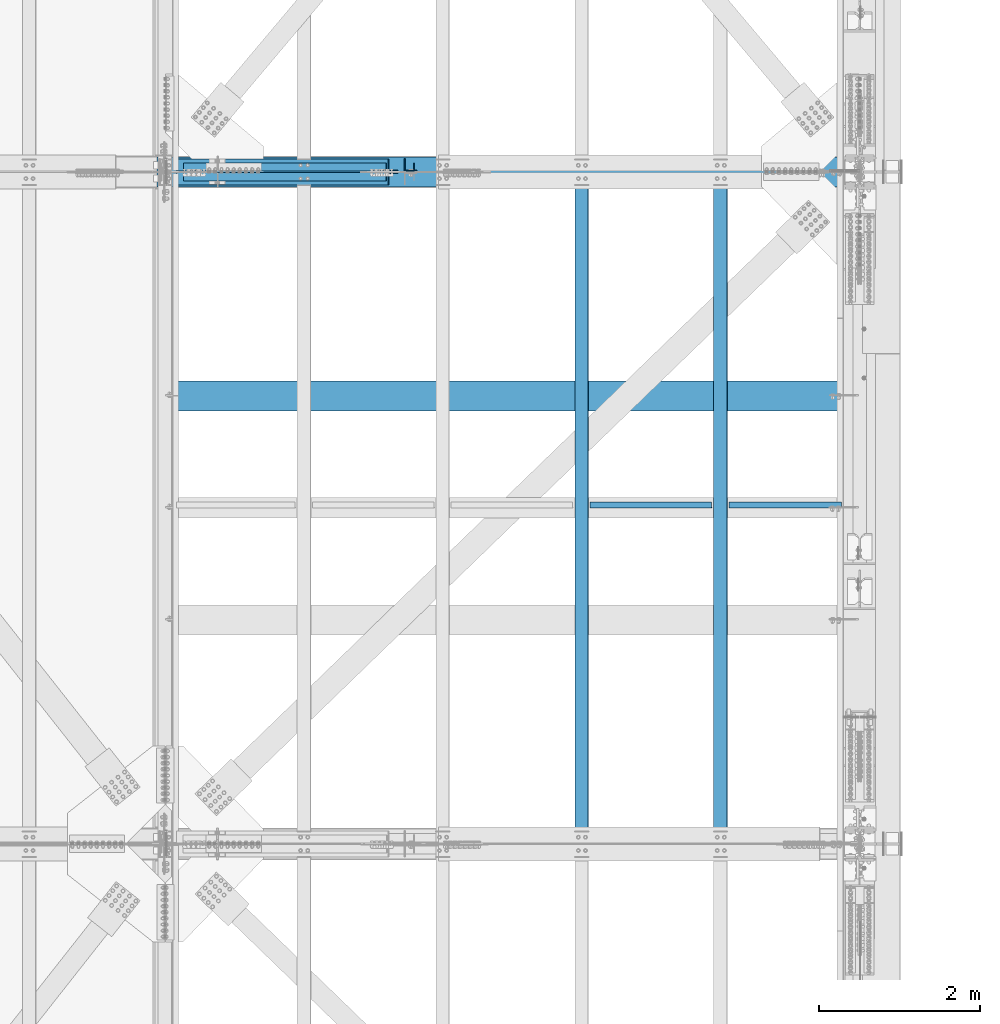
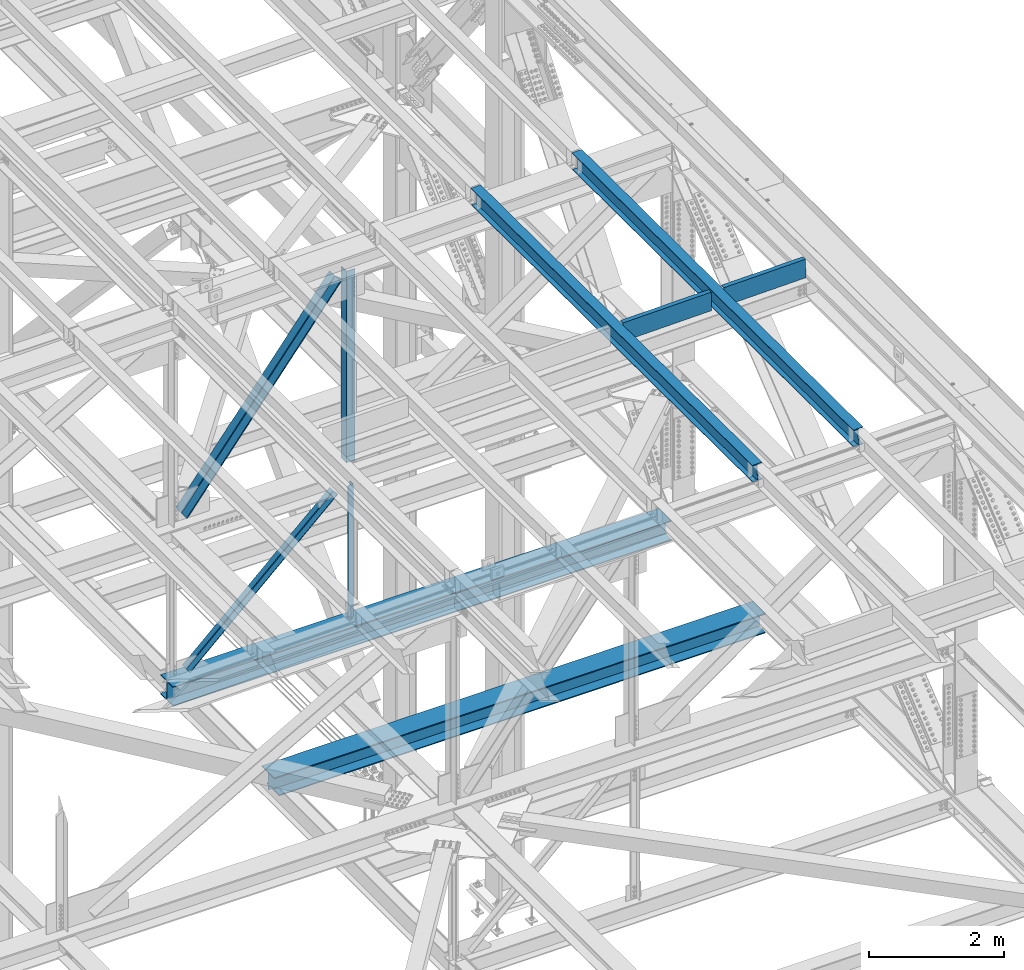
# One storey, part 1983 of 3843: 8 beams, 4 members, 12 elements without a shape of their own.
"""IFC2X3 building model written with IfcOpenShell, lengths in millimetres."""

from ifc_helpers import new_model, si_unit, frame, origin_with_axes, place, context, subcontext, project, spatial, faceted_brep, material, type_object, element, aggregate, save


model = new_model("IFC2X3")

# Units and contexts
model_context = context("Model", 3, precision=1e-05, world=origin_with_axes())
body_context = subcontext(model_context, "Body", "Model", "MODEL_VIEW")
ifc_project = project(units=[si_unit("LENGTHUNIT", "METRE", prefix="MILLI"), si_unit("AREAUNIT", "SQUARE_METRE"), si_unit("VOLUMEUNIT", "CUBIC_METRE"), si_unit("MASSUNIT", "GRAM", prefix="KILO"), si_unit("TIMEUNIT", "SECOND"), si_unit("PLANEANGLEUNIT", "RADIAN"), si_unit("SOLIDANGLEUNIT", "STERADIAN"), si_unit("THERMODYNAMICTEMPERATUREUNIT", "DEGREE_CELSIUS"), si_unit("LUMINOUSINTENSITYUNIT", "LUMEN")], contexts=[model_context])

# Site, building, storey
site_placement = place(None, origin_with_axes())
site = spatial("IfcSite", under=ifc_project, at=site_placement, CompositionType="ELEMENT")
building_placement = place(site_placement, origin_with_axes())
building = spatial("IfcBuilding", under=site, at=building_placement, Name="Undefined", CompositionType="ELEMENT")
storey_placement = place(building_placement, origin_with_axes())
storey = spatial("IfcBuildingStorey", under=building, at=storey_placement, Name="Undefined", CompositionType="ELEMENT", Elevation=0.0)

# Assembly, beam
assembly_1_placement = place(storey_placement, origin_with_axes())
assembly_1 = element("IfcElementAssembly", 1, at=assembly_1_placement, inside=storey, Name="ANGLE", AssemblyPlace="NOTDEFINED", PredefinedType="RIGID_FRAME")
ifc_material_1 = material(Name="STEEL/A572-50")
beam_type_1 = type_object("IfcBeamType", Name="L4X4X3/8", PredefinedType="NOTDEFINED")
beam_1_placement = place(assembly_1_placement, frame((80060.8, 84045.425, 42300.6667680656), z_axis=(-1.0, 0.0, 0.0), x_axis=(0.0, 0.0, -1.0)))
beam_1 = element("IfcBeam", 2, at=beam_1_placement, type_object=beam_type_1, material=ifc_material_1, Name="ANGLE", ObjectType="L4X4X3/8", context=body_context, shape_type="Brep", body=[
    faceted_brep([(248.754579143424, 50.8000000000029, -50.8000000000029), (248.754579143424, 50.8000000000029, 50.8000000000029), (2642.60848138916, 50.8000000000029, 50.8000000000029), (2642.60848138916, 50.8000000000029, -50.8000000000029), (248.754579143424, 41.2749999999942, 50.8000000000029), (2642.60848138916, 41.2749999999942, 50.8000000000029), (248.754579143424, 41.2749999999942, -41.2749999999942), (2642.60848138916, 41.2749999999942, -41.2749999999942), (248.754579143424, -50.8000000000029, -41.2749999999942), (2642.60848138916, -50.8000000000029, -41.2749999999942), (248.754579143424, -50.8000000000029, -50.8000000000029), (2642.60848138916, -50.8000000000029, -50.8000000000029)], [[[0, 1, 2, 3]], [[1, 4, 5, 2]], [[4, 6, 7, 5]], [[6, 8, 9, 7]], [[8, 10, 11, 9]], [[10, 0, 3, 11]], [[5, 7, 9, 11, 3, 2]], [[10, 8, 6, 4, 1, 0]]]),
])
aggregate(assembly_1, [beam_1])

assembly_2_placement = place(storey_placement, origin_with_axes())
assembly_2 = element("IfcElementAssembly", 3, at=assembly_2_placement, inside=storey, Name="BEAM", AssemblyPlace="NOTDEFINED", PredefinedType="RIGID_FRAME")
ifc_material_2 = material(Name="STEEL/A992")
beam_type_2 = type_object("IfcBeamType", Name="W12X26", PredefinedType="NOTDEFINED")
beam_2_placement = place(assembly_2_placement, frame((83918.3092626788, 75629.1553872988, 46633.4435819886), z_axis=(-0.0211520977821055, 0.00421267700001771, 0.99976739400318), x_axis=(0.0, 0.99999112266385, -0.00421361999858334)))
beam_2 = element("IfcBeam", 4, at=beam_2_placement, type_object=beam_type_2, material=ifc_material_2, Name="BEAM", ObjectType="W12X26", context=body_context, shape_type="Brep", body=[
    faceted_brep([(12.7074702028913, 82.5500000014144, -155.574999999284), (12.667344095622, 82.5500000013417, -146.049999999312), (8343.94130358995, 82.550000001429, -146.050000003372), (8343.98142969722, 82.5500000015018, -155.575000003337), (12.660269584725, 3.17500000091968, -146.04999999953), (8343.93422907904, 3.17500000100699, -146.050000003583), (11.4297356284951, 3.17499999911524, 146.049999999537), (8342.70369512282, 3.174999999188, 146.049999995485), (11.436810139392, 82.5499999995518, 146.049999999741), (8342.71076963372, 82.5499999996246, 146.049999995688), (11.3966840321373, 82.5499999994936, 155.574999999713), (8342.67064352645, 82.5499999995664, 155.574999995661), (11.3819690494565, -82.5500000013999, 155.574999999269), (8342.65592854377, -82.5500000013126, 155.574999995217), (11.4220951567113, -82.5500000013271, 146.049999999297), (8342.69605465104, -82.5500000012544, 146.049999995244), (11.4291696676228, -3.17500000090513, 146.049999999508), (8342.70312916195, -3.17500000083237, 146.049999995455), (12.6597036238527, -3.1749999991298, -146.049999999545), (8343.93366311816, -3.17499999904248, -146.050000003605), (12.6526291129412, -82.5499999995518, -146.049999999763), (8343.92658860727, -82.5499999994645, -146.050000003823), (12.6927552202105, -82.5499999994936, -155.574999999735), (8343.96671471454, -82.5499999994063, -155.575000003788)], [[[0, 1, 2, 3]], [[1, 4, 5, 2]], [[4, 6, 7, 5]], [[6, 8, 9, 7]], [[8, 10, 11, 9]], [[10, 12, 13, 11]], [[12, 14, 15, 13]], [[14, 16, 17, 15]], [[16, 18, 19, 17]], [[18, 20, 21, 19]], [[20, 22, 23, 21]], [[22, 0, 3, 23]], [[5, 7, 9, 11, 13, 15, 17, 19, 21, 23, 3, 2]], [[22, 20, 18, 16, 14, 12, 10, 8, 6, 4, 1, 0]]]),
])
aggregate(assembly_2, [beam_2])

assembly_3_placement = place(storey_placement, origin_with_axes())
assembly_3 = element("IfcElementAssembly", 5, at=assembly_3_placement, inside=storey, Name="BEAM", AssemblyPlace="NOTDEFINED", PredefinedType="RIGID_FRAME")
beam_3_placement = place(assembly_3_placement, frame((82191.1092624226, 75629.2591768554, 46601.4357541204), z_axis=(-0.0211520979627239, 0.00487981300159298, 0.999764360325394), x_axis=(0.0, 0.999988088312239, -0.00488090500152411)))
beam_3 = element("IfcBeam", 6, at=beam_3_placement, type_object=beam_type_2, material=ifc_material_2, Name="BEAM", ObjectType="W12X26", context=body_context, shape_type="Brep", body=[
    faceted_brep([(12.7086740090017, 82.5500000002503, -155.575000000361), (12.6621932365233, 82.5500000002503, -146.05000000033), (8343.96143305908, 82.549999999741, -146.049999975774), (8344.00791383155, 82.5499999997264, -155.574999975805), (12.6539983546681, 3.17499999981374, -146.050000000381), (8343.95323817723, 3.17499999928987, -146.049999975825), (11.2285879990668, 3.17500000020664, 146.050000000454), (8342.52782782161, 3.17499999969732, 146.050000025025), (11.2367828809074, 82.5500000006577, 146.050000000505), (8342.53602270348, 82.5500000001339, 146.050000025069), (11.1903021084581, 82.5500000006577, 155.575000000536), (8342.48954193101, 82.5500000001484, 155.575000025092), (11.1732567542058, -82.5500000002503, 155.575000000441), (8342.47249657677, -82.5500000007596, 155.57500002499), (11.2197375266551, -82.5500000002648, 146.050000000403), (8342.51897734923, -82.5500000007887, 146.050000024959), (11.2279324085102, -3.17499999982829, 146.050000000461), (8342.52717223109, -3.1750000003376, 146.05000002501), (12.6533427641261, -3.17500000023574, -146.050000000381), (8343.9525825867, -3.17500000074506, -146.049999975825), (12.645147882271, -82.5500000006723, -146.050000000432), (8343.94438770485, -82.5500000011962, -146.049999975876), (12.6916286547494, -82.5500000006869, -155.575000000455), (8343.9908684773, -82.5500000011962, -155.574999975892)], [[[0, 1, 2, 3]], [[1, 4, 5, 2]], [[4, 6, 7, 5]], [[6, 8, 9, 7]], [[8, 10, 11, 9]], [[10, 12, 13, 11]], [[12, 14, 15, 13]], [[14, 16, 17, 15]], [[16, 18, 19, 17]], [[18, 20, 21, 19]], [[20, 22, 23, 21]], [[22, 0, 3, 23]], [[5, 7, 9, 11, 13, 15, 17, 19, 21, 23, 3, 2]], [[22, 20, 18, 16, 14, 12, 10, 8, 6, 4, 1, 0]]]),
])
aggregate(assembly_3, [beam_3])

# Assembly, member
assembly_4_placement = place(storey_placement, origin_with_axes())
assembly_4 = element("IfcElementAssembly", 7, at=assembly_4_placement, inside=storey, Name="ANGLE", AssemblyPlace="NOTDEFINED", PredefinedType="RIGID_FRAME")
member_type_1 = type_object("IfcMemberType", Name="L4X4X3/8", PredefinedType="NOTDEFINED")
member_1_placement = place(assembly_4_placement, frame((80060.8, 84045.425, 42267.545116169), z_axis=(0.0, 1.0, 0.0), x_axis=(-0.733899008140415, 0.0, -0.679258600129962)))
member_1 = element("IfcMember", 8, at=member_1_placement, type_object=member_type_1, material=ifc_material_1, Name="ANGLE", ObjectType="L4X4X3/8", context=body_context, shape_type="Brep", body=[
    faceted_brep([(363.598779794396, 50.7999999975509, -50.8000000000029), (363.598779794396, 50.7999999975509, 50.8000000000029), (3797.94778411629, 50.7999999761196, 50.8000000000029), (3797.94778411629, 50.7999999761196, -50.8000000000029), (363.598779794484, 41.2749999975786, 50.8000000000029), (3797.94778411639, 41.2749999761545, 50.8000000000029), (363.598779794484, 41.2749999975786, -41.2750000000015), (3797.94778411639, 41.2749999761545, -41.2750000000015), (363.598779795444, -50.8000000021093, -41.2750000000015), (3797.94778411734, -50.8000000235443, -41.2750000000015), (363.598779795444, -50.8000000021093, -50.8000000000029), (3797.94778411734, -50.8000000235443, -50.8000000000029)], [[[0, 1, 2, 3]], [[1, 4, 5, 2]], [[4, 6, 7, 5]], [[6, 8, 9, 7]], [[8, 10, 11, 9]], [[10, 0, 3, 11]], [[5, 7, 9, 11, 3, 2]], [[10, 8, 6, 4, 1, 0]]]),
])
aggregate(assembly_4, [member_1])

assembly_5_placement = place(storey_placement, origin_with_axes())
assembly_5 = element("IfcElementAssembly", 9, at=assembly_5_placement, inside=storey, Name="ANGLE", AssemblyPlace="NOTDEFINED", PredefinedType="RIGID_FRAME")
member_2_placement = place(assembly_5_placement, frame((77012.7999999579, 83924.775, 39446.4754725817), z_axis=(0.0, -1.0, 0.0), x_axis=(0.733899008140419, 0.0, 0.679258600129958)))
member_2 = element("IfcMember", 10, at=member_2_placement, type_object=member_type_1, material=ifc_material_1, Name="ANGLE", ObjectType="L4X4X3/8", context=body_context, shape_type="Brep", body=[
    faceted_brep([(355.212209667981, 50.8000000020438, -50.8000000000029), (355.212209667981, 50.8000000020438, 50.8000000000029), (3789.56121398989, 50.8000000234751, 50.8000000000029), (3789.56121398989, 50.8000000234751, -50.8000000000029), (355.212209667894, 41.2750000020751, 50.8000000000029), (3789.5612139898, 41.2750000235028, 50.8000000000029), (355.212209667894, 41.2750000020751, -41.2750000000015), (3789.5612139898, 41.2750000235028, -41.2750000000015), (355.212209666948, -50.7999999976091, -41.2750000000015), (3789.56121398884, -50.7999999761814, -41.2750000000015), (355.212209666948, -50.7999999976091, -50.8000000000029), (3789.56121398884, -50.7999999761814, -50.8000000000029)], [[[0, 1, 2, 3]], [[1, 4, 5, 2]], [[4, 6, 7, 5]], [[6, 8, 9, 7]], [[8, 10, 11, 9]], [[10, 0, 3, 11]], [[5, 7, 9, 11, 3, 2]], [[10, 8, 6, 4, 1, 0]]]),
])
aggregate(assembly_5, [member_2])

# Assembly, beam
assembly_6_placement = place(storey_placement, origin_with_axes())
assembly_6 = element("IfcElementAssembly", 11, at=assembly_6_placement, inside=storey, Name="BENT_PLATE", AssemblyPlace="NOTDEFINED", PredefinedType="RIGID_FRAME")
ifc_material_3 = material(Name="STEEL/A36")
beam_type_3 = type_object("IfcBeamType", PredefinedType="NOTDEFINED")
beam_4_placement = place(assembly_6_placement, frame((83058.0068169715, 79811.5625000034, 46415.6172205508), z_axis=(-0.999817430718778, 0.0, -0.0191077269946473), x_axis=(-0.0191077269946443, 0.0, 0.999817430718778)))
beam_4 = element("IfcBeam", 12, at=beam_4_placement, type_object=beam_type_3, material=ifc_material_3, Name="BENT_PLATE", context=body_context, shape_type="Brep", body=[
    faceted_brep([(2.38651409745216e-09, -4.76249999999709, -755.649999997448), (-2.37923813983798e-09, -4.76249999999709, 755.649999997433), (-2.37923813983798e-09, 4.76249999999709, 755.649999997433), (2.38651409745216e-09, 4.76249999999709, -755.649999997448), (327.024999945941, 4.76250000002619, 755.650000004171), (327.024999981295, 4.76250000002619, -755.650000004418), (336.549999981282, -4.76249999996799, -755.650000004447), (336.549999945928, -4.76249999996799, 755.650000004156), (327.024999958514, 71.4375000207219, 755.650000005364), (327.024999968708, 71.4375000458094, -755.650000003239), (336.549999958501, 71.4375000207219, 755.650000005349), (336.549999968687, 71.4375000458094, -755.650000003254)], [[[0, 1, 2, 3]], [[3, 2, 4, 5]], [[1, 0, 6, 7]], [[5, 4, 8, 9]], [[4, 2, 1, 7, 10, 8]], [[7, 6, 11, 10]], [[6, 0, 3, 5, 9, 11]], [[10, 11, 9, 8]]]),
])
aggregate(assembly_6, [beam_4])

assembly_7_placement = place(storey_placement, origin_with_axes())
assembly_7 = element("IfcElementAssembly", 13, at=assembly_7_placement, inside=storey, Name="BENT_PLATE", AssemblyPlace="NOTDEFINED", PredefinedType="RIGID_FRAME")
beam_5_placement = place(assembly_7_placement, frame((84727.7934840697, 79811.5625000031, 46446.9663687485), z_axis=(-0.999817430718778, 0.0, -0.0191077269946473), x_axis=(-0.0191077269946443, 0.0, 0.999817430718778)))
beam_5 = element("IfcBeam", 14, at=beam_5_placement, type_object=beam_type_3, material=ifc_material_3, Name="BENT_PLATE", context=body_context, shape_type="Brep", body=[
    faceted_brep([(2.20461515709758e-09, -4.76249999999709, -698.499999997657), (-2.19733919948339e-09, -4.76249999999709, 698.499999997628), (-2.19733919948339e-09, 4.76249999999709, 698.499999997628), (2.20461515709758e-09, 4.76249999999709, -698.499999997657), (327.025000023619, 4.76250000002619, 698.499999999302), (327.025000025125, 4.76250000002619, -698.50000000326), (336.550000025134, -4.76249999996799, -698.500000003318), (336.550000023642, -4.76249999996799, 698.499999999243), (327.025000023437, 71.4374999717184, 698.499999999287), (327.025000025285, 71.4374999714419, -698.500000003274), (336.550000023461, 71.4374999717184, 698.499999999229), (336.550000025301, 71.4374999714419, -698.500000003332)], [[[0, 1, 2, 3]], [[3, 2, 4, 5]], [[1, 0, 6, 7]], [[5, 4, 8, 9]], [[4, 2, 1, 7, 10, 8]], [[7, 6, 11, 10]], [[6, 0, 3, 5, 9, 11]], [[10, 11, 9, 8]]]),
])
aggregate(assembly_7, [beam_5])

# Assembly, member
assembly_8_placement = place(storey_placement, origin_with_axes())
assembly_8 = element("IfcElementAssembly", 15, at=assembly_8_placement, inside=storey, Name="ANGLE", AssemblyPlace="NOTDEFINED", PredefinedType="RIGID_FRAME")
member_type_2 = type_object("IfcMemberType", Name="L6X6X1/2", PredefinedType="NOTDEFINED")
member_3_placement = place(assembly_8_placement, frame((80060.8, 84070.825, 46162.4600971483), z_axis=(0.0, 1.0, 0.0), x_axis=(-0.616143598845406, 0.0, -0.787633839802374)))
member_3 = element("IfcMember", 16, at=member_3_placement, type_object=member_type_2, material=ifc_material_1, Name="ANGLE", ObjectType="L6X6X1/2", context=body_context, shape_type="Brep", body=[
    faceted_brep([(349.413140696022, 76.2000000000116, -76.1999999999971), (349.413140696022, 76.2000000000116, 76.1999999999971), (4621.13277524673, 76.1999999970867, 76.1999999999971), (4621.13277524673, 76.1999999970867, -76.1999999999971), (349.413140696037, 63.4999999999782, 76.1999999999971), (4621.13277524675, 63.499999997046, 76.1999999999971), (349.413140696037, 63.4999999999782, -63.5), (4621.13277524675, 63.499999997046, -63.5), (349.413140696022, -76.2000000005064, -63.5), (4621.13277524673, -76.2000000034313, -63.5), (349.413140696022, -76.2000000005064, -76.1999999999971), (4621.13277524673, -76.2000000034313, -76.1999999999971)], [[[0, 1, 2, 3]], [[1, 4, 5, 2]], [[4, 6, 7, 5]], [[6, 8, 9, 7]], [[8, 10, 11, 9]], [[10, 0, 3, 11]], [[5, 7, 9, 11, 3, 2]], [[10, 8, 6, 4, 1, 0]]]),
])
aggregate(assembly_8, [member_3])

assembly_9_placement = place(storey_placement, origin_with_axes())
assembly_9 = element("IfcElementAssembly", 17, at=assembly_9_placement, inside=storey, Name="ANGLE", AssemblyPlace="NOTDEFINED", PredefinedType="RIGID_FRAME")
member_4_placement = place(assembly_9_placement, frame((77012.800000048, 83899.375, 42266.1152420207), z_axis=(0.0, -1.0, 0.0), x_axis=(0.616143598845403, 0.0, 0.787633839802376)))
member_4 = element("IfcMember", 18, at=member_4_placement, type_object=member_type_2, material=ifc_material_1, Name="ANGLE", ObjectType="L6X6X1/2", context=body_context, shape_type="Brep", body=[
    faceted_brep([(325.765973476678, 76.2000000004773, -76.1999999999971), (325.765973476678, 76.2000000004773, 76.1999999999971), (4597.48560802739, 76.2000000034022, 76.1999999999971), (4597.48560802739, 76.2000000034022, -76.1999999999971), (325.765973476678, 63.5000000004293, 76.1999999999971), (4597.48560802739, 63.5000000033615, 76.1999999999971), (325.765973476678, 63.5000000004293, -63.5), (4597.48560802739, 63.5000000033615, -63.5), (325.765973476664, -76.2000000000407, -63.5), (4597.48560802739, -76.1999999971231, -63.5), (325.765973476664, -76.2000000000407, -76.1999999999971), (4597.48560802739, -76.1999999971231, -76.1999999999971)], [[[0, 1, 2, 3]], [[1, 4, 5, 2]], [[4, 6, 7, 5]], [[6, 8, 9, 7]], [[8, 10, 11, 9]], [[10, 0, 3, 11]], [[5, 7, 9, 11, 3, 2]], [[10, 8, 6, 4, 1, 0]]]),
])
aggregate(assembly_9, [member_4])

# Assembly, beam
assembly_10_placement = place(storey_placement, origin_with_axes())
assembly_10 = element("IfcElementAssembly", 19, at=assembly_10_placement, inside=storey, Name="ANGLE", AssemblyPlace="NOTDEFINED", PredefinedType="RIGID_FRAME")
beam_type_4 = type_object("IfcBeamType", Name="L6X6X1/2", PredefinedType="NOTDEFINED")
beam_6_placement = place(assembly_10_placement, frame((80060.8, 84070.825, 46162.3813904932), z_axis=(0.0, 1.0, 0.0), x_axis=(0.0, 0.0, -1.0)))
beam_6 = element("IfcBeam", 20, at=beam_6_placement, type_object=beam_type_4, material=ifc_material_1, Name="ANGLE", ObjectType="L6X6X1/2", context=body_context, shape_type="Brep", body=[
    faceted_brep([(224.130687771685, 76.1999999999971, -76.1999999999971), (224.130687771685, 76.1999999999971, 76.1999999999971), (3685.38512490015, 76.1999999999971, 76.1999999999971), (3685.38512490015, 76.1999999999971, -76.1999999999971), (224.130687771685, 63.5, 76.1999999999971), (3685.38512490015, 63.5, 76.1999999999971), (224.130687771685, 63.5, -63.5), (3685.38512490015, 63.5, -63.5), (224.130687771685, -76.1999999999971, -63.5), (3685.38512490015, -76.1999999999971, -63.5), (224.130687771685, -76.1999999999971, -76.1999999999971), (3685.38512490015, -76.1999999999971, -76.1999999999971)], [[[0, 1, 2, 3]], [[1, 4, 5, 2]], [[4, 6, 7, 5]], [[6, 8, 9, 7]], [[8, 10, 11, 9]], [[10, 0, 3, 11]], [[5, 7, 9, 11, 3, 2]], [[10, 8, 6, 4, 1, 0]]]),
])
aggregate(assembly_10, [beam_6])

assembly_11_placement = place(storey_placement, origin_with_axes())
assembly_11 = element("IfcElementAssembly", 21, at=assembly_11_placement, inside=storey, Name="BEAM", AssemblyPlace="NOTDEFINED", PredefinedType="RIGID_FRAME")
beam_type_5 = type_object("IfcBeamType", Name="W14X90", PredefinedType="NOTDEFINED")
beam_7_placement = place(assembly_11_placement, frame((76910.7190632656, 83985.1, 39446.1993495485), z_axis=(-0.002704930999098, 0.0, 0.999996341667453), x_axis=(0.999996341667453, 0.0, 0.00270493099910052)))
beam_7 = element("IfcBeam", 22, at=beam_7_placement, type_object=beam_type_5, material=ifc_material_2, Name="BEAM", ObjectType="W14X90", context=body_context, shape_type="Brep", body=[
    faceted_brep([(3.34694050252438e-10, 184.149999999994, -177.80000000052), (3.05590219795704e-10, 184.149999999994, -160.337500000467), (8521.77841028498, 184.149999999994, -160.337499983645), (8521.73117525462, 184.149999999994, -177.79999998369), (3.05590219795704e-10, 5.55624999999418, -160.337500000467), (8521.77841028498, 5.55624999999418, -160.337499983645), (-3.20142135024071e-10, 5.55624999999418, 160.33750000046), (8522.64581720637, 5.55624999999418, 160.337500017282), (-3.20142135024071e-10, 184.149999999994, 160.33750000046), (8522.64581720637, 184.149999999994, 160.337500017282), (-3.49245965480804e-10, 184.149999999994, 177.800000000512), (8522.69305223675, 184.149999999994, 177.800000017334), (-3.49245965480804e-10, -184.149999999994, 177.800000000512), (8522.69305223675, -184.149999999994, 177.800000017334), (-3.20142135024071e-10, -184.149999999994, 160.33750000046), (8522.64581720637, -184.149999999994, 160.337500017282), (-3.20142135024071e-10, -5.55624999999418, 160.33750000046), (8522.64581720637, -5.55624999999418, 160.337500017282), (3.05590219795704e-10, -5.55624999999418, -160.337500000467), (8521.77841028498, -5.55624999999418, -160.337499983645), (3.05590219795704e-10, -184.149999999994, -160.337500000467), (8521.77841028498, -184.149999999994, -160.337499983645), (3.34694050252438e-10, -184.149999999994, -177.80000000052), (8521.73117525462, -184.149999999994, -177.79999998369)], [[[0, 1, 2, 3]], [[1, 4, 5, 2]], [[4, 6, 7, 5]], [[6, 8, 9, 7]], [[8, 10, 11, 9]], [[10, 12, 13, 11]], [[12, 14, 15, 13]], [[14, 16, 17, 15]], [[16, 18, 19, 17]], [[18, 20, 21, 19]], [[20, 22, 23, 21]], [[22, 0, 3, 23]], [[5, 7, 9, 11, 13, 15, 17, 19, 21, 23, 3, 2]], [[22, 20, 18, 16, 14, 12, 10, 8, 6, 4, 1, 0]]]),
])
aggregate(assembly_11, [beam_7])

assembly_12_placement = place(storey_placement, origin_with_axes())
assembly_12 = element("IfcElementAssembly", 23, at=assembly_12_placement, inside=storey, Name="BEAM", AssemblyPlace="NOTDEFINED", PredefinedType="RIGID_FRAME")
beam_8_placement = place(assembly_12_placement, frame((77012.0859280208, 81198.442196, 39446.1985660831), z_axis=(-0.00401615300090635, 0.0, 0.999991935225016), x_axis=(0.999991935225016, 0.0, 0.00401615300090405)))
beam_8 = element("IfcBeam", 24, at=beam_8_placement, type_object=beam_type_5, material=ifc_material_2, Name="BEAM", ObjectType="W14X90", context=body_context, shape_type="Brep", body=[
    faceted_brep([(18.3839110966655, -5.55624999999418, -146.0499999967), (18.3839110966655, 5.55624999999418, -146.0499999967), (94.4563974007469, 5.55624999999418, -146.049999999617), (94.4563974007469, -5.55624999999418, -146.049999999617), (99.3164769188734, 5.55624999999418, -147.016729922238), (99.3164769188734, -5.55624999999418, -147.016729922238), (103.436653387122, 5.55624999999418, -149.769743822791), (103.436653387122, -5.55624999999418, -149.769743822791), (106.189667287676, 5.55624999999418, -153.889920291032), (106.189667287676, -5.55624999999418, -153.889920291032), (107.156397210303, -5.55624999999418, -158.749999809166), (107.156397210303, 5.55624999999418, -158.749999809166), (107.156397210303, 5.55624999999418, -160.337500000613), (107.156397210303, 184.149999999994, -160.337500000613), (107.156397210114, 184.149999999994, -177.80000000065), (107.156397210114, -184.149999999994, -177.80000000065), (107.156397210303, -184.149999999994, -160.337500000613), (107.156397210303, -5.55624999999418, -160.337500000613), (19.6144200957642, 5.55624999999418, 160.337500000205), (19.6144200957642, 184.149999999994, 160.337500000205), (8421.52592965006, 184.149999999994, 160.337499974004), (8421.52592965006, 5.55624999999418, 160.337499974004), (19.6845527330443, 184.149999999994, 177.800000000243), (8421.59606228731, 184.149999999994, 177.799999974042), (19.6845527330443, -184.149999999994, 177.800000000243), (8421.59606228731, -184.149999999994, 177.799999974042), (19.6144200957642, -184.149999999994, 160.337500000205), (8421.52592965006, -184.149999999994, 160.337499974004), (19.6144200957642, -5.55624999999418, 160.337500000205), (8421.52592965006, -5.55624999999418, 160.337499974004), (8420.23803940228, 5.55624999999418, -160.337500026537), (8420.23803940228, -5.55624999999418, -160.337500026537), (8420.23803940228, -184.149999999994, -160.337500026537), (8420.16790676503, -184.149999999994, -177.800000026567), (8420.16790676503, 184.149999999994, -177.800000026567), (8420.23803940228, 184.149999999994, -160.337500026537), (18.5549165164557, 5.55624999999418, -103.470934673569), (19.4810413967934, 5.55624999999418, 127.127205590099)], [[[0, 1, 2, 3]], [[3, 2, 4, 5]], [[5, 4, 6, 7]], [[7, 6, 8, 9]], [[10, 11, 12, 13, 14, 15, 16, 17]], [[9, 8, 11, 10]], [[18, 19, 20, 21]], [[19, 22, 23, 20]], [[22, 24, 25, 23]], [[24, 26, 27, 25]], [[26, 28, 29, 27]], [[30, 21, 20, 23, 25, 27, 29, 31, 32, 33, 34, 35]], [[32, 31, 17, 16]], [[33, 32, 16, 15]], [[34, 33, 15, 14]], [[35, 34, 14, 13]], [[30, 35, 13, 12]], [[6, 4, 2, 1, 36, 37, 18, 21, 30, 12, 11, 8]], [[28, 26, 24, 22, 19, 18, 37, 36, 1, 0]], [[31, 29, 28, 0, 3, 5, 7, 9, 10, 17]]]),
])
aggregate(assembly_12, [beam_8])

save(model, "model.ifc")
